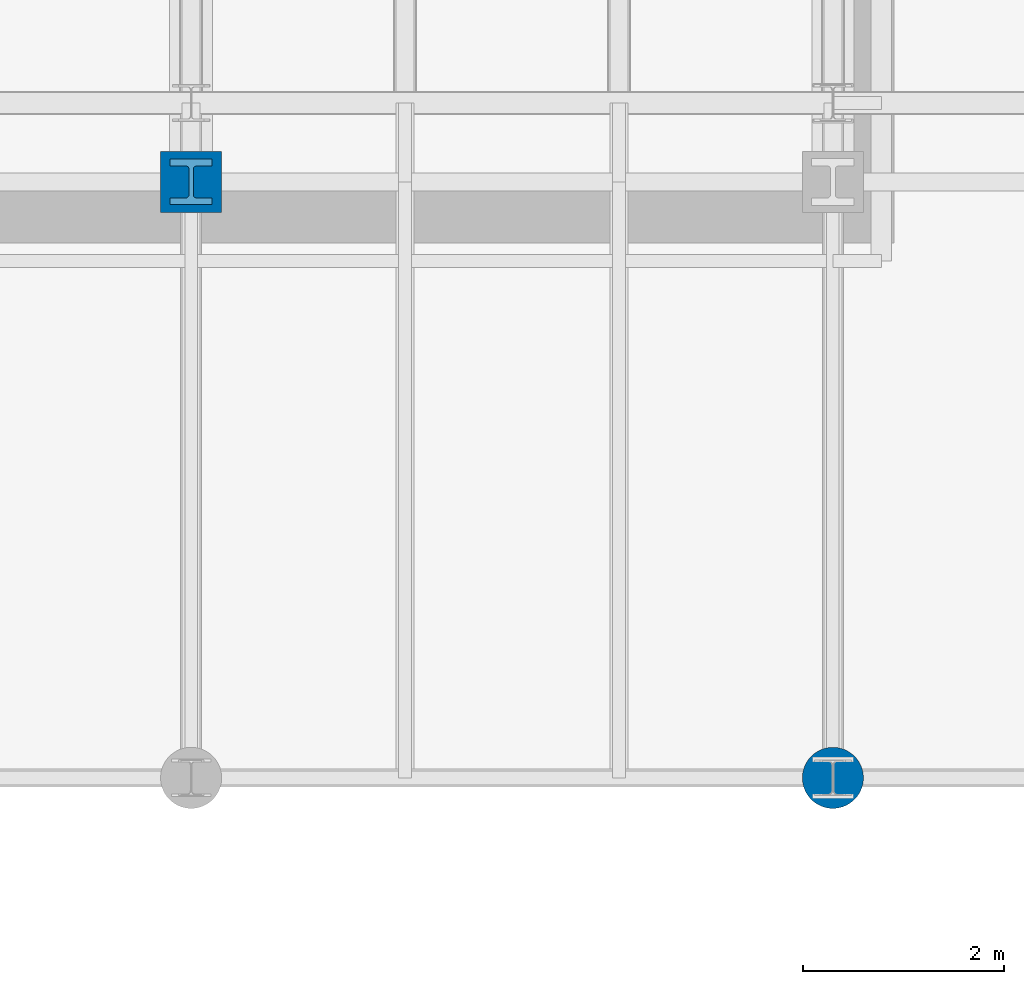
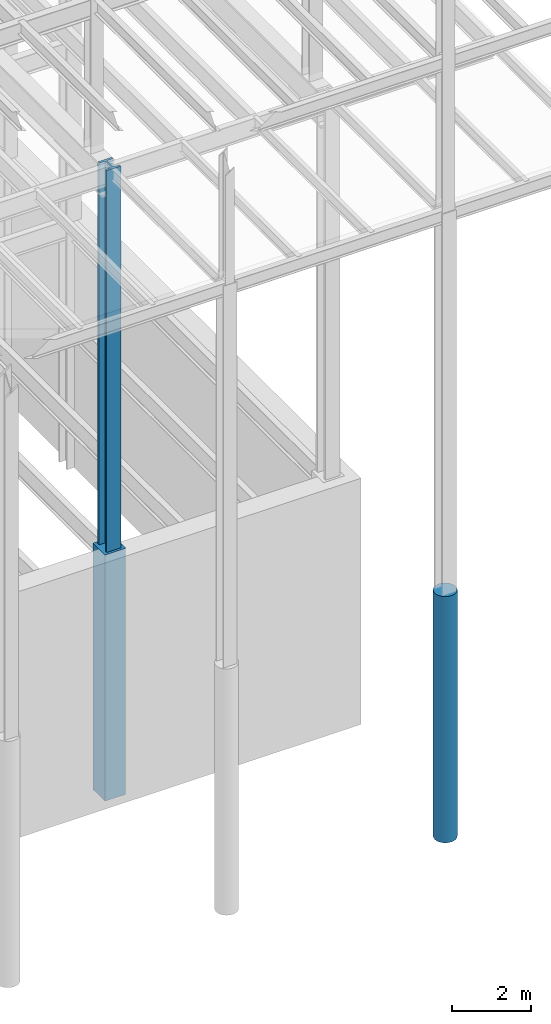
# One storey, part 83 of 150: 3 columns.
"""IFC2X3 building model written with IfcOpenShell, lengths in millimetres."""

from ifc_helpers import new_model, si_unit, frame, origin_with_axes, origin_2d_with_axis, place, context, subcontext, project, spatial, rectangle, circle, i_section, extrude, material, type_object, element, save


model = new_model("IFC2X3")

# Units and contexts
model_context = context("Model", 3, precision=1e-05, world=origin_with_axes())
body_context = subcontext(model_context, "Body", "Model", "MODEL_VIEW")
ifc_project = project(units=[si_unit("LENGTHUNIT", "METRE", prefix="MILLI"), si_unit("AREAUNIT", "SQUARE_METRE"), si_unit("VOLUMEUNIT", "CUBIC_METRE"), si_unit("MASSUNIT", "GRAM", prefix="KILO"), si_unit("TIMEUNIT", "SECOND"), si_unit("PLANEANGLEUNIT", "RADIAN"), si_unit("SOLIDANGLEUNIT", "STERADIAN"), si_unit("THERMODYNAMICTEMPERATUREUNIT", "DEGREE_CELSIUS"), si_unit("LUMINOUSINTENSITYUNIT", "LUMEN")], contexts=[model_context])

# Site, building, storey
site_placement = place(None, origin_with_axes())
site = spatial("IfcSite", under=ifc_project, at=site_placement, CompositionType="ELEMENT")
building_placement = place(site_placement, origin_with_axes())
building = spatial("IfcBuilding", under=site, at=building_placement, Name="Undefined", CompositionType="ELEMENT")
storey_placement = place(building_placement, origin_with_axes())
storey = spatial("IfcBuildingStorey", under=building, at=storey_placement, Name="Undefined", CompositionType="ELEMENT", Elevation=0.0)

# Columns
ifc_material_1 = material(Name="STEEL/A992")
column_type_1 = type_object("IfcColumnType", Name="W14X370", PredefinedType="NOTDEFINED")
column_1_placement = place(storey_placement, frame((82194.4, 9398.0, 22707.6), z_axis=(0.0, 0.0, 1.0), x_axis=(1.0, 0.0, 0.0)))
element("IfcColumn", 1, at=column_1_placement, inside=storey, type_object=column_type_1, material=ifc_material_1, Name="COLUMN", ObjectType="W14X370", context=body_context, shape_type="SweptSolid", body=[
    extrude(i_section(OverallWidth=419.1, OverallDepth=454.025, WebThickness=42.8625, FlangeThickness=67.564, FilletRadius=32.4484, at=origin_2d_with_axis()), frame((0.0, 0.0, 12877.8), z_axis=(0.0, 0.0, -1.0), x_axis=(-1.0, 0.0, 0.0)), (0.0, 0.0, 1.0), 12877.8),
])
ifc_material_2 = material(Name="CONCRETE/5000")
column_type_2 = type_object("IfcColumnType", PredefinedType="NOTDEFINED")
column_2_placement = place(storey_placement, frame((88595.2, 3454.40000000001, 16154.4), z_axis=(0.0, 0.0, 1.0), x_axis=(1.0, 0.0, 0.0)))
element("IfcColumn", 2, at=column_2_placement, inside=storey, type_object=column_type_2, material=ifc_material_2, Name="COLUMN", context=body_context, shape_type="SweptSolid", body=[
    extrude(circle(Radius=304.8, at=origin_2d_with_axis()), frame((0.0, 0.0, 7620.0), z_axis=(0.0, 0.0, -1.0), x_axis=(0.0, -1.0, 0.0)), (0.0, 0.0, 1.0), 7619.99999999999),
])
column_type_3 = type_object("IfcColumnType", PredefinedType="NOTDEFINED")
column_3_placement = place(storey_placement, frame((82194.4, 9398.0, 16154.4), z_axis=(0.0, 0.0, 1.0), x_axis=(1.0, 0.0, 0.0)))
element("IfcColumn", 3, at=column_3_placement, inside=storey, type_object=column_type_3, material=ifc_material_2, Name="COLUMN", context=body_context, shape_type="SweptSolid", body=[
    extrude(rectangle(XDim=609.6, YDim=609.6, at=origin_2d_with_axis()), frame((0.0, 0.0, 7620.0), z_axis=(0.0, 0.0, -1.0), x_axis=(0.0, -1.0, 0.0)), (0.0, 0.0, 1.0), 7620.0),
])

save(model, "model.ifc")
